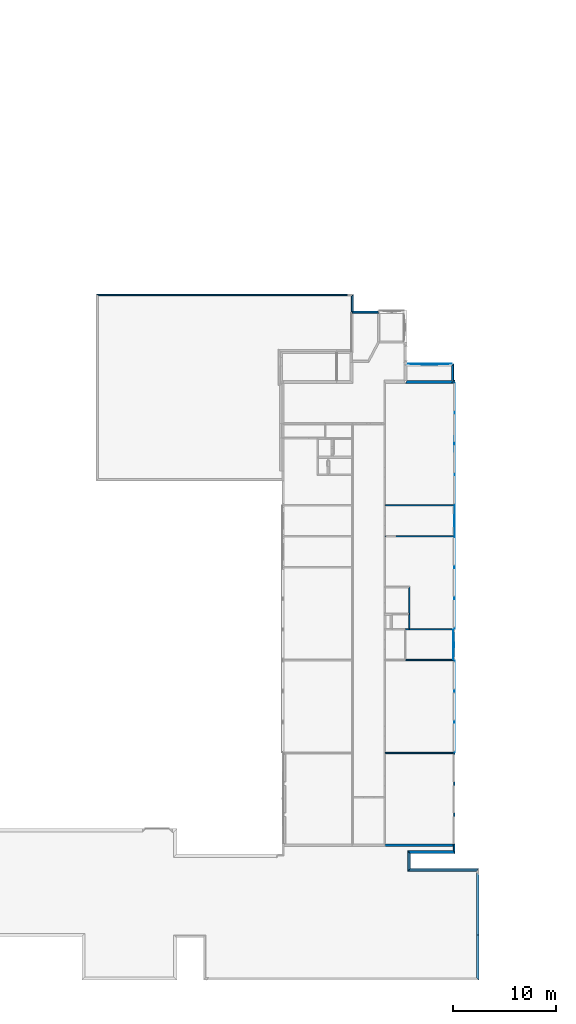
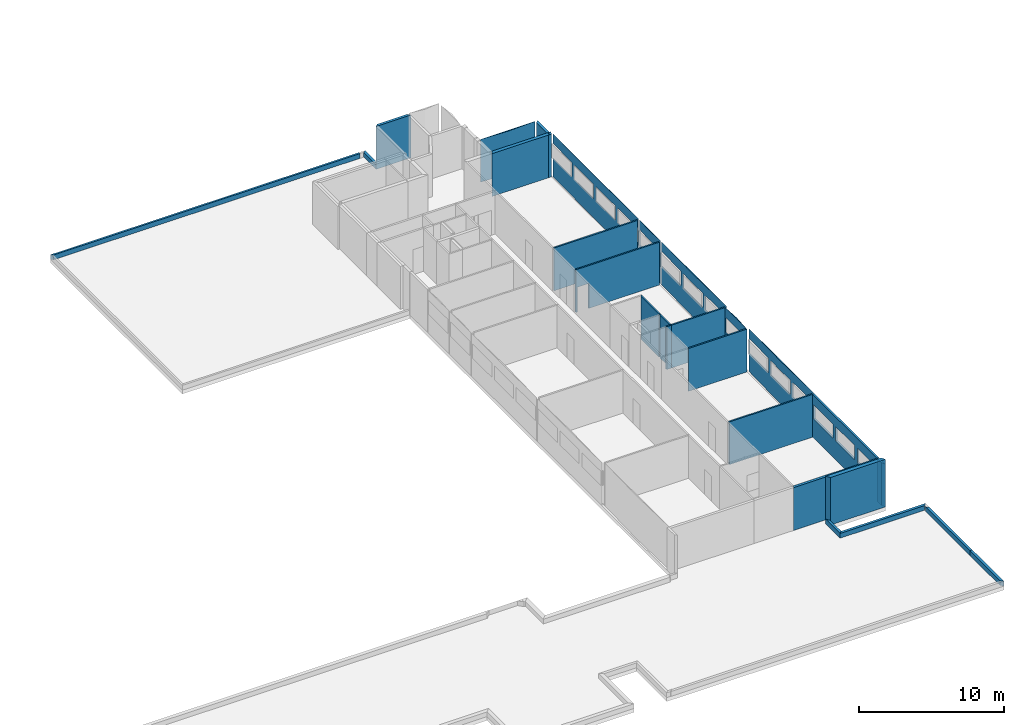
# One storey, part 5 of 72: 28 walls, 16 openings.
"""IFC2X3 building model written with IfcOpenShell, lengths in metres."""

from ifc_helpers import new_model, entity, si_unit, converted_unit, derived_unit, frame, origin_with_axes, place, context, project, spatial, polyline, outline, extrude, material, layer, layer_set, layer_usage, element, save


model = new_model("IFC2X3")

# Units and contexts
context_of_model_1 = context(None, 3, world=origin_with_axes())
context_of_model_2 = context(None, 3, world=origin_with_axes())
context_of_model_3 = context(None, 2, world=origin_with_axes())
context_of_model_4 = context(None, 3, world=origin_with_axes())
ifc_project = project(units=[si_unit("LENGTHUNIT", "METRE"), si_unit("AREAUNIT", "SQUARE_METRE"), si_unit("ELECTRICCURRENTUNIT", "AMPERE"), si_unit("ELECTRICVOLTAGEUNIT", "VOLT"), si_unit("ELECTRICRESISTANCEUNIT", "OHM"), si_unit("POWERUNIT", "WATT"), si_unit("MASSUNIT", "GRAM"), si_unit("SOLIDANGLEUNIT", "STERADIAN"), si_unit("THERMODYNAMICTEMPERATUREUNIT", "KELVIN"), si_unit("PRESSUREUNIT", "PASCAL"), si_unit("LUMINOUSFLUXUNIT", "LUMEN"), si_unit("ILLUMINANCEUNIT", "LUX"), si_unit("FREQUENCYUNIT", "HERTZ"), si_unit("VOLUMEUNIT", "CUBIC_METRE"), si_unit("TIMEUNIT", "SECOND"), derived_unit("VOLUMETRICFLOWRATEUNIT", [(si_unit("TIMEUNIT", "SECOND"), -1), (si_unit("VOLUMEUNIT", "CUBIC_METRE"), 1)]), derived_unit("THERMALTRANSMITTANCEUNIT", [(si_unit("AREAUNIT", "SQUARE_METRE"), -1), (si_unit("THERMODYNAMICTEMPERATUREUNIT", "KELVIN"), -1), (si_unit("POWERUNIT", "WATT"), 1)]), converted_unit("PLANEANGLEUNIT", "DEGREE", entity("IfcPlaneAngleMeasure", 57.29577951308232), si_unit("PLANEANGLEUNIT", "RADIAN"), dimensions=[0, 0, 0, 0, 0, 0, 0])], contexts=[context_of_model_1, context_of_model_2, context_of_model_3, context_of_model_4])

# Site, building, storey
site = spatial("IfcSite", under=ifc_project, CompositionType="ELEMENT")
building_placement = place(None, origin_with_axes())
building = spatial("IfcBuilding", under=site, at=building_placement, Name="200", CompositionType="ELEMENT")
storey_placement = place(building_placement, frame((0.0, 0.0, 15.68000030517578), z_axis=(0.0, 0.0, 1.0), x_axis=(1.0, 0.0, 0.0)))
storey = spatial("IfcBuildingStorey", under=building, at=storey_placement, Name="3.etasje", CompositionType="ELEMENT", Elevation=15.68000030517578)

# Walls
ifc_material_1 = material(Name="Layer-YV04 20 cm")
ifc_layer_1 = layer(ifc_material_1, 0.2000000029802322, ventilated=False)
ifc_layer_set_1 = layer_set([ifc_layer_1])
ifc_layer_usage_1 = layer_usage(ifc_layer_set_1, "AXIS2", "POSITIVE", 0.0)
wall_1_placement = place(storey_placement, frame((12.73623752593994, -12.12827587127686, 0.0), z_axis=(0.0, 0.0, 1.0), x_axis=(-4.371138828673793e-08, 1.0, 0.0)))
element("IfcWallStandardCase", 1, at=wall_1_placement, inside=storey, material=ifc_layer_usage_1, Name="YV04 20 cm", context=context_of_model_1, shape_type="SweptSolid", body=[
    extrude(outline(polyline([(0.0, 0.0), (4.360269546508788, 0.0), (4.360269546508788, 0.1999998092651369), (0.1999998092651382, 0.2000017166137685), (0.0, 0.0)])), frame((0.0, 0.0, 0.0), z_axis=(0.0, 0.0, 1.0), x_axis=(0.9999999999999992, -4.371139013701908e-08, 0.0)), (0.0, 0.0, 1.0), 0.4),
])
wall_2_placement = place(storey_placement, frame((12.73623752593994, -7.768006324768066, 0.0), z_axis=(0.0, 0.0, 1.0), x_axis=(-4.371138828673793e-08, 1.0, 0.0)))
element("IfcWallStandardCase", 2, at=wall_2_placement, inside=storey, material=ifc_layer_usage_1, Name="YV04 20 cm", context=context_of_model_1, shape_type="SweptSolid", body=[
    extrude(outline(polyline([(0.0, 0.0), (5.894350409507751, 0.0), (6.094350337982176, 0.1999998092651373), (-5.330077061348608e-16, 0.1999998092651369), (0.0, 0.0)])), frame((0.0, 0.0, 0.0), z_axis=(0.0, 0.0, 1.0), x_axis=(0.9999999999999991, -4.371139000564226e-08, 0.0)), (0.0, 0.0, 1.0), 0.4),
])
wall_3_placement = place(storey_placement, frame((12.73922824859619, -1.31800639629364, 0.0), z_axis=(0.0, 0.0, 1.0), x_axis=(-1.0, 1.509958025280866e-07, 0.0)))
element("IfcWallStandardCase", 3, at=wall_3_placement, inside=storey, material=ifc_layer_usage_1, Name="YV04 20 cm", context=context_of_model_1, shape_type="SweptSolid", body=[
    extrude(outline(polyline([(0.0, 0.0), (6.699837684631374, 0.0), (6.899837476103643, 0.2000000654765604), (0.199999791472271, 0.2000000654765604), (0.0, 0.0)])), frame((0.0, 0.0, 0.0), z_axis=(0.0, 0.0, 1.0), x_axis=(0.9999999999999981, 6.203148745014698e-08, 0.0)), (0.0, 0.0, 1.0), 0.4),
])
wall_4_placement = place(storey_placement, frame((6.039390563964844, -1.318005800247192, 0.0), z_axis=(0.0, 0.0, 1.0), x_axis=(-4.371138828673793e-08, 1.0, 0.0)))
element("IfcWallStandardCase", 4, at=wall_4_placement, inside=storey, material=ifc_layer_usage_1, Name="YV04 20 cm", context=context_of_model_1, shape_type="SweptSolid", body=[
    extrude(outline(polyline([(0.0, 0.0), (1.49888500571251, 0.0), (1.798884987831116, 0.1999998092651371), (-0.2000000476837157, 0.1999998092651366), (0.0, 0.0)])), frame((0.0, 0.0, 0.0), z_axis=(0.0, 0.0, 1.0), x_axis=(0.999999999999999, -4.371139009486238e-08, 0.0)), (0.0, 0.0, 1.0), 0.4),
])
ifc_material_2 = material(Name="Layer-YV3 30 cm")
ifc_layer_2 = layer(ifc_material_2, 0.300000011920929, ventilated=False)
ifc_layer_set_2 = layer_set([ifc_layer_2])
ifc_layer_usage_2 = layer_usage(ifc_layer_set_2, "AXIS2", "POSITIVE", 0.0)
wall_5_placement = place(storey_placement, frame((6.039390563964844, 0.1808792054653168, 0.0), z_axis=(0.0, 0.0, 1.0), x_axis=(1.0, 6.81067069407959e-09, 0.0)))
element("IfcWallStandardCase", 5, at=wall_5_placement, inside=storey, material=ifc_layer_usage_2, Name="YV3 30 cm", context=context_of_model_1, shape_type="SweptSolid", body=[
    extrude(outline(polyline([(0.0, 0.0), (4.375827789306641, 0.0), (4.224827768461658, 0.3000000129493404), (-0.1999998072219355, 0.3000000728877066), (0.0, 0.0)])), frame((0.0, 0.0, 0.0), z_axis=(0.0, 0.0, 1.0), x_axis=(1.0, 6.977224572640124e-17, 0.0)), (0.0, 0.0, 1.0), 4.0),
])
ifc_material_3 = material(Name="Layer-YV3 15 cm")
ifc_layer_3 = layer(ifc_material_3, 0.1507492065429688, ventilated=False)
ifc_layer_set_3 = layer_set([ifc_layer_3])
ifc_layer_usage_3 = layer_usage(ifc_layer_set_3, "AXIS2", "POSITIVE", 0.0)
wall_6_placement = place(storey_placement, frame((10.41521835327148, 0.1808792352676392, 0.0), z_axis=(0.0, 0.0, 1.0), x_axis=(-4.371138828673793e-08, 1.0, 0.0)))
element("IfcWallStandardCase", 6, at=wall_6_placement, inside=storey, material=ifc_layer_usage_3, Name="YV3 15 cm", context=context_of_model_1, shape_type="SweptSolid", body=[
    extrude(outline(polyline([(0.0, 0.0), (0.9119060039520263, 6.617444900424221e-24), (0.9119060039520264, 0.1510000228881837), (0.300000011920929, 0.1510000228881831), (0.0, 0.0)])), frame((0.0, 0.0, 0.0), z_axis=(0.0, 0.0, 1.0), x_axis=(0.9999999999999991, -4.371138926696568e-08, 0.0)), (0.0, 0.0, 1.0), 3.6),
])
ifc_material_4 = material(Name="Layer-YV3 15 cm")
ifc_layer_4 = layer(ifc_material_4, 0.2713470458984375, ventilated=False)
ifc_layer_set_4 = layer_set([ifc_layer_4])
ifc_layer_usage_4 = layer_usage(ifc_layer_set_4, "AXIS2", "POSITIVE", 0.0)
wall_7_placement = place(storey_placement, frame((10.41521644592285, 46.24888610839844, 0.0), z_axis=(0.0, 0.0, 1.0), x_axis=(-1.0, -8.742277657347586e-08, 0.0)))
element("IfcWallStandardCase", 7, at=wall_7_placement, inside=storey, material=ifc_layer_usage_4, Name="YV3 15 cm", context=context_of_model_1, shape_type="SweptSolid", body=[
    extrude(outline(polyline([(0.0, 0.0), (0.1205959320068364, 0.0), (0.3205957412719667, 0.2713470458984368), (0.1004962921142528, 0.2713470458984298), (0.0, 0.0)])), frame((0.0, 0.0, 0.0), z_axis=(0.0, 0.0, 1.0), x_axis=(0.9999999999999962, -8.742280096682447e-08, 0.0)), (0.0, 0.0, 1.0), 3.6),
])
wall_8_placement = place(storey_placement, frame((2.875983953475952, 53.00139999389648, 0.0), z_axis=(0.0, 0.0, 1.0), x_axis=(-1.0, -8.742277657347586e-08, 0.0)))
element("IfcWallStandardCase", 8, at=wall_8_placement, inside=storey, material=ifc_layer_usage_1, Name="YV04 20 cm", context=context_of_model_1, shape_type="SweptSolid", body=[
    extrude(outline(polyline([(0.0, 0.0), (2.372065007686615, 0.0), (2.572064876556397, 0.200000762939453), (-0.2000000476837156, 0.2000007629394535), (0.0, 0.0)])), frame((0.0, 0.0, 0.0), z_axis=(0.0, 0.0, 1.0), x_axis=(0.9999999999999962, -8.742277927956448e-08, 0.0)), (0.0, 0.0, 1.0), 3.6),
])
wall_9_placement = place(storey_placement, frame((0.5039189457893372, 53.00139999389648, 0.0), z_axis=(0.0, 0.0, 1.0), x_axis=(-4.371138828673793e-08, 1.0, 0.0)))
element("IfcWallStandardCase", 9, at=wall_9_placement, inside=storey, material=ifc_layer_usage_1, Name="YV04 20 cm", context=context_of_model_1, shape_type="SweptSolid", body=[
    extrude(outline(polyline([(0.0, 0.0), (1.641052246093743, 0.0), (1.491050727479033, 0.199999993527275), (-0.2000007556752632, 0.1999999357386521), (0.0, 0.0)])), frame((0.0, 0.0, 0.0), z_axis=(0.0, 0.0, 1.0), x_axis=(1.0, -7.390398479739984e-09, 0.0)), (0.0, 0.0, 1.0), 0.4),
])
ifc_material_5 = material(Name="Layer-YV3 15 cm")
ifc_layer_5 = layer(ifc_material_5, 0.1500000059604645, ventilated=False)
ifc_layer_set_5 = layer_set([ifc_layer_5])
ifc_layer_usage_5 = layer_usage(ifc_layer_set_5, "AXIS2", "POSITIVE", 0.0)
wall_10_placement = place(storey_placement, frame((1.370906829833984e-06, 54.64245223999023, 0.0), z_axis=(0.0, 0.0, 1.0), x_axis=(-1.0, -8.742277657347586e-08, 0.0)))
element("IfcWallStandardCase", 10, at=wall_10_placement, inside=storey, material=ifc_layer_usage_5, Name="YV3 15 cm", context=context_of_model_1, shape_type="SweptSolid", body=[
    extrude(outline(polyline([(0.0, 0.0), (24.49093002080918, 0.0), (24.3409304022789, 0.1500015258789091), (-5.872947607540769e-18, 0.1500015258789068), (0.0, 0.0)])), frame((0.0, 0.0, 0.0), z_axis=(0.0, 0.0, 1.0), x_axis=(0.9999999999999962, -8.742278004287902e-08, 0.0)), (0.0, 0.0, 1.0), 0.4),
])
ifc_material_6 = material()
ifc_layer_6 = layer(ifc_material_6, 0.2713546752929688, ventilated=False)
ifc_layer_set_6 = layer_set([ifc_layer_6])
ifc_layer_usage_6 = layer_usage(ifc_layer_set_6, "AXIS2", "POSITIVE", 0.0)
wall_11_placement = place(storey_placement, frame((5.597535610198975, 45.9775390625, 0.0), z_axis=(0.0, 0.0, 1.0), x_axis=(1.0, 0.0, 0.0)))
element("IfcWallStandardCase", 11, at=wall_11_placement, inside=storey, material=ifc_layer_usage_6, context=context_of_model_1, shape_type="SweptSolid", body=[
    extrude(outline(polyline([(0.0, 0.0), (4.717184543609619, 0.0), (4.497085094451904, 0.2713470458984375), (0.1507501602172852, 0.2713470458984375), (0.0, 0.0)])), origin_with_axes(), (0.0, 0.0, 1.0), 3.6),
])
wall_12_placement = place(storey_placement, frame((10.29462051391602, 46.24888610839844, 0.0), z_axis=(0.0, 0.0, 1.0), x_axis=(-4.371138828673793e-08, 1.0, 0.0)))
element("IfcWallStandardCase", 12, at=wall_12_placement, inside=storey, material=ifc_layer_usage_1, Name="YV04 20 cm", context=context_of_model_1, shape_type="SweptSolid", body=[
    extrude(outline(polyline([(0.0, 0.0), (1.618358612060549, 0.0), (1.418357849121095, 0.1999998092651374), (-4.712814208746225e-16, 0.1999998092651369), (0.0, 0.0)])), frame((0.0, 0.0, 0.0), z_axis=(0.0, 0.0, 1.0), x_axis=(0.999999999999999, -4.371138969701054e-08, 0.0)), (0.0, 0.0, 1.0), 3.6),
])
wall_13_placement = place(storey_placement, frame((10.09462070465088, 47.66724395751953, 0.0), z_axis=(0.0, 0.0, 1.0), x_axis=(-1.0, -8.742277657347586e-08, 0.0)))
element("IfcWallStandardCase", 13, at=wall_13_placement, inside=storey, material=ifc_layer_usage_1, Name="YV04 20 cm", context=context_of_model_1, shape_type="SweptSolid", body=[
    extrude(outline(polyline([(0.0, 0.0), (4.346334934234621, 0.0), (9.264004803512326e-16, 0.2000007629394539), (4.346334934234621, 0.2000007629394539), (0.0, 0.0)])), frame((0.0, 0.0, 0.0), z_axis=(0.0, 0.0, -1.0), x_axis=(0.9999999999999961, -8.742277989276747e-08, 0.0)), (0.0, 0.0, -1.0), 3.6),
])
ifc_material_7 = material()
ifc_layer_7 = layer(ifc_material_7, 0.2000000029802322, ventilated=False)
ifc_layer_set_7 = layer_set([ifc_layer_7])
ifc_layer_usage_7 = layer_usage(ifc_layer_set_7, "AXIS2", "POSITIVE", 0.0)
wall_14_placement = place(storey_placement, frame((3.517215251922607, 0.892785370349884, 0.0), z_axis=(0.0, 0.0, 1.0), x_axis=(1.0, -1.728171028503311e-08, 0.0)))
element("IfcWallStandardCase", 14, at=wall_14_placement, inside=storey, material=ifc_layer_usage_7, context=context_of_model_1, shape_type="SweptSolid", body=[
    extrude(outline(polyline([(0.0, 0.0), (6.898003101348877, 0.0), (6.747254845023884, 0.1999999854738835), (0.1205987895734455, 0.1999998709539348), (0.0, 0.0)])), frame((0.0, 0.0, 0.0), z_axis=(0.0, 0.0, 1.0), x_axis=(1.0, 2.253278538206629e-16, 0.0)), (0.0, 0.0, 1.0), 3.6),
])

# Wall, openings
wall_15_placement = place(storey_placement, frame((10.41521835327148, 1.092785239219666, 0.0), z_axis=(0.0, 0.0, 1.0), x_axis=(-4.371138828673793e-08, 1.0, 0.0)))
wall_15 = element("IfcWallStandardCase", 15, at=wall_15_placement, inside=storey, material=ifc_layer_usage_3, Name="YV3 15 cm", context=context_of_model_1, shape_type="SweptSolid", body=[
    extrude(outline(polyline([(0.0, 0.0), (8.893602013587952, 0.0), (8.8333021402359, 0.1507482528686515), (2.386872670913614e-18, 0.1507482528686525), (0.0, 0.0)])), frame((0.0, 0.0, 0.0), z_axis=(0.0, 0.0, 1.0), x_axis=(0.999999999999999, -4.371139002933706e-08, 0.0)), (0.0, 0.0, 1.0), 3.6),
])
opening_1_placement = place(wall_15_placement, frame((0.03767181101751627, 0.1507482512219642, 1.6), z_axis=(0.0, 0.0, 1.0), x_axis=(1.0, 0.0, 0.0)))
element("IfcOpeningElement", 16, at=opening_1_placement, cuts=wall_15, context=context_of_model_1, shape_type="SweptSolid", body=[
    extrude(outline(polyline([(0.0, 0.0), (1.200000047683716, 0.0), (1.200000047683716, 2.658), (0.0, 2.658), (0.0, 0.0)])), frame((0.0, 0.0, 0.0), z_axis=(4.371139016334065e-08, 0.999999999999999, 0.0), x_axis=(0.0, 0.0, 1.0)), (0.0, 4.371139016334065e-08, -0.9999999999999991), 0.1507479793622988),
])
opening_2_placement = place(wall_15_placement, frame((3.051244861516475, 0.150748119494498, 1.6), z_axis=(0.0, 0.0, 1.0), x_axis=(1.0, 0.0, 0.0)))
element("IfcOpeningElement", 17, at=opening_2_placement, cuts=wall_15, context=context_of_model_1, shape_type="SweptSolid", body=[
    extrude(outline(polyline([(0.0, 0.0), (1.200000047683716, 0.0), (1.200000047683716, 2.658), (0.0, 2.658), (0.0, 0.0)])), frame((0.0, 0.0, 0.0), z_axis=(4.371139016334065e-08, 0.999999999999999, 0.0), x_axis=(0.0, 0.0, 1.0)), (0.0, 4.371139016334065e-08, -0.9999999999999991), 0.1507479793622988),
])
opening_3_placement = place(wall_15_placement, frame((6.062531597051141, 0.1507479878669695, 1.6), z_axis=(0.0, 0.0, 1.0), x_axis=(1.0, 0.0, 0.0)))
element("IfcOpeningElement", 18, at=opening_3_placement, cuts=wall_15, context=context_of_model_1, shape_type="SweptSolid", body=[
    extrude(outline(polyline([(0.0, 0.0), (1.200000047683716, 0.0), (1.200000047683716, 2.657999999999999), (0.0, 2.657999999999999), (0.0, 0.0)])), frame((0.0, 0.0, 0.0), z_axis=(4.371139016334066e-08, 0.999999999999999, 0.0), x_axis=(0.0, 0.0, 1.0)), (0.0, 4.371139016334067e-08, -0.9999999999999992), 0.1507479793622988),
])

# Wall
ifc_material_8 = material()
ifc_layer_8 = layer(ifc_material_8, 0.121002197265625, ventilated=False)
ifc_layer_set_8 = layer_set([ifc_layer_8])
ifc_layer_usage_8 = layer_usage(ifc_layer_set_8, "AXIS2", "POSITIVE", 0.0)
wall_16_placement = place(storey_placement, frame((10.26447010040283, 10.04668712615967, 0.0), z_axis=(0.0, 0.0, 1.0), x_axis=(-1.0, -8.742277657347586e-08, 0.0)))
element("IfcWallStandardCase", 19, at=wall_16_placement, inside=storey, material=ifc_layer_usage_8, context=context_of_model_1, shape_type="SweptSolid", body=[
    extrude(outline(polyline([(0.0, 0.0), (6.626655817031862, 0.0), (6.62665605545044, 0.1205997467041033), (-5.852870015015086e-16, 0.120599746704102), (0.0, 0.0)])), frame((0.0, 0.0, 0.0), z_axis=(0.0, 0.0, 1.0), x_axis=(0.9999999999999961, -8.742278020508375e-08, 0.0)), (0.0, 0.0, 1.0), 3.6),
])

# Wall, openings
wall_17_placement = place(storey_placement, frame((10.26447010040283, 10.04668712615967, 0.0), z_axis=(0.0, 0.0, 1.0), x_axis=(-4.371138828673793e-08, 1.0, 0.0)))
wall_17 = element("IfcWallStandardCase", 20, at=wall_17_placement, inside=storey, material=ifc_layer_usage_3, Name="YV3 15 cm", context=context_of_model_1, shape_type="SweptSolid", body=[
    extrude(outline(polyline([(0.0, 0.0), (8.921465873718263, 5.293955920339377e-23), (-1.336499008280796e-15, 0.1507482528686525), (8.921465873718265, 0.1507482528686525), (0.0, 0.0)])), frame((0.0, 0.0, 0.0), z_axis=(0.0, 0.0, -1.0), x_axis=(0.999999999999999, -4.371139001710141e-08, 0.0)), (0.0, 0.0, -1.0), 3.6),
])
opening_4_placement = place(wall_17_placement, frame((0.1222047805786133, -5.341741271536193e-09, 1.6), z_axis=(0.0, 0.0, 1.0), x_axis=(1.0, 0.0, 0.0)))
element("IfcOpeningElement", 21, at=opening_4_placement, cuts=wall_17, context=context_of_model_1, shape_type="SweptSolid", body=[
    extrude(outline(polyline([(0.0, 0.0), (1.200000047683716, 0.0), (1.200000047683716, 2.658223152160645), (0.0, 2.658223152160645), (0.0, 0.0)])), frame((0.0, 0.0, 0.0), z_axis=(4.371139004455655e-08, 0.999999999999999, 0.0), x_axis=(0.0, 0.0, 1.0)), (0.0, 4.371139004455655e-08, -0.9999999999999991), 0.1507478970506907),
])
opening_5_placement = place(wall_17_placement, frame((3.135777473449705, -1.370691915525413e-07, 1.6), z_axis=(0.0, 0.0, 1.0), x_axis=(1.0, 0.0, 0.0)))
element("IfcOpeningElement", 22, at=opening_5_placement, cuts=wall_17, context=context_of_model_1, shape_type="SweptSolid", body=[
    extrude(outline(polyline([(0.0, 0.0), (1.200000047683716, 0.0), (1.200000047683716, 2.658223152160643), (0.0, 2.658223152160643), (0.0, 0.0)])), frame((0.0, 0.0, 0.0), z_axis=(4.371139004455659e-08, 0.999999999999999, 0.0), x_axis=(0.0, 0.0, 1.0)), (0.0, 4.371139004455659e-08, -0.9999999999999991), 0.1507478970506907),
])
opening_6_placement = place(wall_17_placement, frame((6.14706325531005, -2.686966791287659e-07, 1.6), z_axis=(0.0, 0.0, 1.0), x_axis=(1.0, 0.0, 0.0)))
element("IfcOpeningElement", 23, at=opening_6_placement, cuts=wall_17, context=context_of_model_1, shape_type="SweptSolid", body=[
    extrude(outline(polyline([(0.0, 0.0), (1.200000047683716, 0.0), (1.200000047683716, 2.658226013183596), (0.0, 2.658226013183596), (0.0, 0.0)])), frame((0.0, 0.0, 0.0), z_axis=(4.371138977583923e-08, 0.999999999999999, 0.0), x_axis=(0.0, 0.0, 1.0)), (0.0, 4.371138977583923e-08, -0.9999999999999992), 0.1507478970506907),
])

# Wall
ifc_material_9 = material()
ifc_layer_9 = layer(ifc_material_9, 0.1205999851226807, ventilated=False)
ifc_layer_set_9 = layer_set([ifc_layer_9])
ifc_layer_usage_9 = layer_usage(ifc_layer_set_9, "AXIS2", "POSITIVE", 0.0)
wall_18_placement = place(storey_placement, frame((10.26447010040283, 19.08875274658203, 0.0), z_axis=(0.0, 0.0, 1.0), x_axis=(-1.0, -8.742277657347586e-08, 0.0)))
element("IfcWallStandardCase", 24, at=wall_18_placement, inside=storey, material=ifc_layer_usage_9, context=context_of_model_1, shape_type="SweptSolid", body=[
    extrude(outline(polyline([(0.0, 0.0), (4.616654396057129, 5.293955920339377e-23), (4.66690492630005, 0.1205997467041025), (-5.63108305699853e-16, 0.120599746704102), (0.0, 0.0)])), frame((0.0, 0.0, 0.0), z_axis=(0.0, 0.0, 1.0), x_axis=(0.9999999999999961, -8.742278002118041e-08, 0.0)), (0.0, 0.0, 1.0), 3.6),
])

# Wall, opening
wall_19_placement = place(storey_placement, frame((10.26447010040283, 19.08875274658203, 0.0), z_axis=(0.0, 0.0, 1.0), x_axis=(-4.371138828673793e-08, 1.0, 0.0)))
wall_19 = element("IfcWallStandardCase", 25, at=wall_19_placement, inside=storey, material=ifc_layer_usage_3, Name="YV3 15 cm", context=context_of_model_1, shape_type="SweptSolid", body=[
    extrude(outline(polyline([(0.0, 0.0), (2.879892349243163, 0.0), (2.222884016867664e-15, 0.1507482528686525), (2.879892349243165, 0.1507482528686525), (0.0, 0.0)])), frame((0.0, 0.0, 0.0), z_axis=(0.0, 0.0, -1.0), x_axis=(0.9999999999999991, -4.371139006134301e-08, 0.0)), (0.0, 0.0, -1.0), 3.6),
])
opening_7_placement = place(wall_19_placement, frame((0.1162853240966797, -5.082993581595474e-09, 1.6), z_axis=(0.0, 0.0, 1.0), x_axis=(1.0, 0.0, 0.0)))
element("IfcOpeningElement", 26, at=opening_7_placement, cuts=wall_19, context=context_of_model_1, shape_type="SweptSolid", body=[
    extrude(outline(polyline([(0.0, 0.0), (1.200000047683716, 0.0), (1.200000047683716, 2.658226013183593), (0.0, 2.658226013183593), (0.0, 0.0)])), frame((0.0, 0.0, 0.0), z_axis=(4.371138977583929e-08, 0.999999999999999, 0.0), x_axis=(0.0, 0.0, 1.0)), (0.0, 4.371138977583929e-08, -0.9999999999999992), 0.1507480645228533),
])

# Walls
wall_20_placement = place(storey_placement, frame((10.26447010040283, 22.08924674987793, 0.0), z_axis=(0.0, 0.0, 1.0), x_axis=(-1.0, -8.742277657347586e-08, 0.0)))
element("IfcWallStandardCase", 27, at=wall_20_placement, inside=storey, material=ifc_layer_usage_9, context=context_of_model_1, shape_type="SweptSolid", body=[
    extrude(outline(polyline([(0.0, 0.0), (4.226655006408691, 0.0), (4.288655281066894, 0.1206016540527345), (-3.028357307454183e-16, 0.1206016540527348), (0.0, 0.0)])), frame((0.0, 0.0, 0.0), z_axis=(0.0, 0.0, 1.0), x_axis=(0.9999999999999962, -8.742277978528296e-08, 0.0)), (0.0, 0.0, 1.0), 3.6),
])
wall_21_placement = place(storey_placement, frame((5.913814544677734, 22.08924674987793, 0.0), z_axis=(0.0, 0.0, 1.0), x_axis=(-1.0, -8.742277657347586e-08, 0.0)))
element("IfcWallStandardCase", 28, at=wall_21_placement, inside=storey, material=ifc_layer_usage_8, context=context_of_model_1, shape_type="SweptSolid", body=[
    extrude(outline(polyline([(0.0, 0.0), (0.3162493705749515, 0.0), (0.2659988403320311, 0.1206016540527344), (-0.06200027465820365, 0.1206016540527352), (0.0, 0.0)])), frame((0.0, 0.0, 0.0), z_axis=(0.0, 0.0, 1.0), x_axis=(0.9999999999999961, -8.742277964556659e-08, 0.0)), (0.0, 0.0, 1.0), 3.6),
])

# Wall, openings
wall_22_placement = place(storey_placement, frame((10.26447010040283, 22.08924674987793, 0.0), z_axis=(0.0, 0.0, 1.0), x_axis=(-4.371138828673793e-08, 1.0, 0.0)))
wall_22 = element("IfcWallStandardCase", 29, at=wall_22_placement, inside=storey, material=ifc_layer_usage_3, Name="YV3 15 cm", context=context_of_model_1, shape_type="SweptSolid", body=[
    extrude(outline(polyline([(0.0, 0.0), (8.93182373046875, 0.0), (2.211804669580442e-15, 0.1507482528686525), (8.931823730468748, 0.1507472991943361), (0.0, 0.0)])), frame((0.0, 0.0, 0.0), z_axis=(0.0, 0.0, -1.0), x_axis=(0.999999999999999, -4.371138998784733e-08, 0.0)), (0.0, 0.0, -1.0), 3.6),
])
opening_8_placement = place(wall_22_placement, frame((0.1242580413818359, -5.431491700846891e-09, 1.6), z_axis=(0.0, 0.0, 1.0), x_axis=(1.0, 0.0, 0.0)))
element("IfcOpeningElement", 30, at=opening_8_placement, cuts=wall_22, context=context_of_model_1, shape_type="SweptSolid", body=[
    extrude(outline(polyline([(0.0, 0.0), (1.200000047683716, 0.0), (1.200000047683716, 2.65822410583496), (0.0, 2.65822410583496), (0.0, 0.0)])), frame((0.0, 0.0, 0.0), z_axis=(4.371138973223426e-08, 0.999999999999999, 0.0), x_axis=(0.0, 0.0, 1.0)), (0.0, 4.371138973223427e-08, -0.9999999999999992), 0.1507475447914773),
])
opening_9_placement = place(wall_22_placement, frame((3.133426666259762, -1.369664346384525e-07, 1.6), z_axis=(0.0, 0.0, 1.0), x_axis=(1.0, 0.0, 0.0)))
element("IfcOpeningElement", 31, at=opening_9_placement, cuts=wall_22, context=context_of_model_1, shape_type="SweptSolid", body=[
    extrude(outline(polyline([(0.0, 0.0), (1.200000047683716, 0.0), (1.200000047683716, 2.658226013183593), (0.0, 2.658226013183593), (0.0, 0.0)])), frame((0.0, 0.0, 0.0), z_axis=(4.371139044408828e-08, 0.999999999999999, 0.0), x_axis=(0.0, 0.0, 1.0)), (0.0, 4.371139044408828e-08, -0.9999999999999992), 0.1507475447914773),
])
opening_10_placement = place(wall_22_placement, frame((6.155366897583001, -2.690596438981174e-07, 1.6), z_axis=(0.0, 0.0, 1.0), x_axis=(1.0, 0.0, 0.0)))
element("IfcOpeningElement", 32, at=opening_10_placement, cuts=wall_22, context=context_of_model_1, shape_type="SweptSolid", body=[
    extrude(outline(polyline([(0.0, 0.0), (1.200000047683716, 0.0), (1.200000047683716, 2.658227920532225), (0.0, 2.658227920532225), (0.0, 0.0)])), frame((0.0, 0.0, 0.0), z_axis=(4.371138981944425e-08, 0.999999999999999, 0.0), x_axis=(0.0, 0.0, 1.0)), (0.0, 4.371138981944425e-08, -0.9999999999999991), 0.1507475447914773),
])

# Wall, opening
wall_23_placement = place(storey_placement, frame((10.26447010040283, 31.14167213439941, 0.0), z_axis=(0.0, 0.0, 1.0), x_axis=(-1.0, -8.742277657347586e-08, 0.0)))
wall_23 = element("IfcWallStandardCase", 33, at=wall_23_placement, inside=storey, material=ifc_layer_usage_8, context=context_of_model_1, shape_type="SweptSolid", body=[
    extrude(outline(polyline([(0.0, 0.0), (6.626655340194701, 0.0), (6.626655340194701, 0.1206016540527348), (-3.039164951552781e-16, 0.1206016540527348), (0.0, 0.0)])), frame((0.0, 0.0, 0.0), z_axis=(0.0, 0.0, 1.0), x_axis=(0.9999999999999962, -8.742277979424439e-08, 0.0)), (0.0, 0.0, 1.0), 3.6),
])
opening_11_placement = place(wall_23_placement, frame((5.615690718703711, 0.1206011631134416, 0.0), z_axis=(0.0, 0.0, 1.0), x_axis=(1.0, 0.0, 0.0)))
element("IfcOpeningElement", 34, at=opening_11_placement, cuts=wall_23, context=context_of_model_1, shape_type="SweptSolid", body=[
    extrude(outline(polyline([(0.0, 0.0), (2.099999904632568, 0.0), (2.099999904632568, 0.9145500659942627), (0.0, 0.9145500659942627), (0.0, 0.0)])), frame((0.0, 0.0, 0.0), z_axis=(8.742277739647082e-08, 0.9999999999999962, 0.0), x_axis=(0.0, 0.0, 1.0)), (0.0, 8.742277739647082e-08, -0.9999999999999962), 0.1206016540527344),
])

# Walls
ifc_material_10 = material()
ifc_layer_10 = layer(ifc_material_10, 0.1238250732421875, ventilated=False)
ifc_layer_set_10 = layer_set([ifc_layer_10])
ifc_layer_usage_10 = layer_usage(ifc_layer_set_10, "AXIS2", "POSITIVE", 0.0)
wall_24_placement = place(storey_placement, frame((5.913814544677734, 26.06524467468262, 0.0), z_axis=(0.0, 0.0, 1.0), x_axis=(-4.371138828673793e-08, -1.0, 0.0)))
element("IfcWallStandardCase", 35, at=wall_24_placement, inside=storey, material=ifc_layer_usage_10, context=context_of_model_1, shape_type="SweptSolid", body=[
    extrude(outline(polyline([(0.0, 0.0), (2.499856948852541, 0.0), (2.561857223510744, 0.1240005493164056), (-0.1240005493164067, 0.1240005493164061), (0.0, 0.0)])), frame((0.0, 0.0, 0.0), z_axis=(0.0, 0.0, 1.0), x_axis=(0.9999999999999991, 4.371139013847142e-08, 0.0)), (0.0, 0.0, 1.0), 3.6),
])
wall_25_placement = place(storey_placement, frame((5.913814544677734, 23.44138908386231, 0.0), z_axis=(0.0, 0.0, 1.0), x_axis=(-4.371138828673793e-08, -1.0, 0.0)))
element("IfcWallStandardCase", 36, at=wall_25_placement, inside=storey, material=ifc_layer_usage_10, context=context_of_model_1, shape_type="SweptSolid", body=[
    extrude(outline(polyline([(0.0, 0.0), (1.352142333984373, 0.0), (1.352142333984373, 0.1240005493164064), (-0.06199836730957069, 0.1240005493164064), (0.0, 0.0)])), frame((0.0, 0.0, 0.0), z_axis=(0.0, 0.0, 1.0), x_axis=(0.999999999999999, 4.371139024884114e-08, 0.0)), (0.0, 0.0, 1.0), 3.6),
])

# Wall, opening
wall_26_placement = place(storey_placement, frame((10.26447010040283, 31.14167213439941, 0.0), z_axis=(0.0, 0.0, 1.0), x_axis=(-4.371138828673793e-08, 1.0, 0.0)))
wall_26 = element("IfcWallStandardCase", 37, at=wall_26_placement, inside=storey, material=ifc_layer_usage_3, Name="YV3 15 cm", context=context_of_model_1, shape_type="SweptSolid", body=[
    extrude(outline(polyline([(0.0, 0.0), (2.893617630004882, 2.646977960169689e-23), (-3.322798351085354e-16, 0.1507472991943361), (2.893617630004882, 0.1507472991943361), (0.0, 0.0)])), frame((0.0, 0.0, 0.0), z_axis=(0.0, 0.0, -1.0), x_axis=(0.9999999999999991, -4.371139040241523e-08, 0.0)), (0.0, 0.0, -1.0), 3.6),
])
opening_12_placement = place(wall_26_placement, frame((0.1142311096191406, -4.993200519720631e-09, 1.6), z_axis=(0.0, 0.0, 1.0), x_axis=(1.0, 0.0, 0.0)))
element("IfcOpeningElement", 38, at=opening_12_placement, cuts=wall_26, context=context_of_model_1, shape_type="SweptSolid", body=[
    extrude(outline(polyline([(0.0, 0.0), (1.200000047683716, 0.0), (1.200000047683716, 2.65822410583496), (0.0, 2.65822410583496), (0.0, 0.0)])), frame((0.0, 0.0, 0.0), z_axis=(4.371139040048373e-08, 0.999999999999999, 0.0), x_axis=(0.0, 0.0, 1.0)), (0.0, 4.371139040048374e-08, -0.9999999999999992), 0.1507472991943359),
])

# Wall
ifc_material_11 = material()
ifc_layer_11 = layer(ifc_material_11, 0.1259994506835938, ventilated=False)
ifc_layer_set_11 = layer_set([ifc_layer_11])
ifc_layer_usage_11 = layer_usage(ifc_layer_set_11, "AXIS2", "POSITIVE", 0.0)
wall_27_placement = place(storey_placement, frame((10.31472015380859, 34.16091156005859, 0.0), z_axis=(0.0, 0.0, 1.0), x_axis=(-1.0, -8.742277657347586e-08, 0.0)))
element("IfcWallStandardCase", 39, at=wall_27_placement, inside=storey, material=ifc_layer_usage_11, context=context_of_model_1, shape_type="SweptSolid", body=[
    extrude(outline(polyline([(0.0, 0.0), (6.676905393600465, -1.058791184067875e-22), (6.676905393600466, 0.1256217956542974), (0.05025005340576251, 0.1256217956543023), (0.0, 0.0)])), frame((0.0, 0.0, 0.0), z_axis=(0.0, 0.0, 1.0), x_axis=(0.9999999999999961, -8.742277958634203e-08, 0.0)), (0.0, 0.0, 1.0), 3.6),
])

# Wall, openings
ifc_material_12 = material(Name="Layer-YV3 15 cm")
ifc_layer_12 = layer(ifc_material_12, 0.100496303348809, ventilated=False)
ifc_layer_set_12 = layer_set([ifc_layer_12])
ifc_layer_usage_12 = layer_usage(ifc_layer_set_12, "AXIS2", "POSITIVE", 0.0)
wall_28_placement = place(storey_placement, frame((10.31472015380859, 34.16091156005859, 0.0), z_axis=(0.0, 0.0, 1.0), x_axis=(-4.371138828673793e-08, 1.0, 0.0)))
wall_28 = element("IfcWallStandardCase", 40, at=wall_28_placement, inside=storey, material=ifc_layer_usage_12, Name="YV3 15 cm", context=context_of_model_1, shape_type="SweptSolid", body=[
    extrude(outline(polyline([(0.0, 0.0), (11.81662750244141, 0.0), (6.851271083481599e-16, 0.1004972457885743), (11.81662750244141, 0.1004962921142579), (0.0, 0.0)])), frame((0.0, 0.0, 0.0), z_axis=(0.0, 0.0, -1.0), x_axis=(0.9999999999999991, -4.371139000950112e-08, 0.0)), (0.0, 0.0, -1.0), 3.6),
])
opening_13_placement = place(wall_28_placement, frame((0.1062812805175781, -4.645702489369796e-09, 1.6), z_axis=(0.0, 0.0, 1.0), x_axis=(1.0, 0.0, 0.0)))
element("IfcOpeningElement", 41, at=opening_13_placement, cuts=wall_28, context=context_of_model_1, shape_type="SweptSolid", body=[
    extrude(outline(polyline([(0.0, 0.0), (1.200000047683716, 0.0), (1.200000047683716, 2.65822219848633), (0.0, 2.65822219848633), (0.0, 0.0)])), frame((0.0, 0.0, 0.0), z_axis=(4.371138968862912e-08, 0.999999999999999, 0.0), x_axis=(0.0, 0.0, 1.0)), (0.0, 4.371138968862912e-08, -0.9999999999999991), 0.100496303348809),
])
opening_14_placement = place(wall_28_placement, frame((3.122135162353516, -1.364728667851978e-07, 1.6), z_axis=(0.0, 0.0, 1.0), x_axis=(1.0, 0.0, 0.0)))
element("IfcOpeningElement", 42, at=opening_14_placement, cuts=wall_28, context=context_of_model_1, shape_type="SweptSolid", body=[
    extrude(outline(polyline([(0.0, 0.0), (1.200000047683716, 0.0), (1.200000047683716, 2.658226013183589), (0.0, 2.658226013183589), (0.0, 0.0)])), frame((0.0, 0.0, 0.0), z_axis=(4.371139044408833e-08, 0.999999999999999, 0.0), x_axis=(0.0, 0.0, 1.0)), (0.0, 4.371139044408833e-08, -0.9999999999999991), 0.100496303348809),
])
opening_15_placement = place(wall_28_placement, frame((6.133422851562493, -2.681004378501939e-07, 1.6), z_axis=(0.0, 0.0, 1.0), x_axis=(1.0, 0.0, 0.0)))
element("IfcOpeningElement", 43, at=opening_15_placement, cuts=wall_28, context=context_of_model_1, shape_type="SweptSolid", body=[
    extrude(outline(polyline([(0.0, 0.0), (1.200000047683716, 0.0), (1.200000047683716, 2.658226013183596), (0.0, 2.658226013183596), (0.0, 0.0)])), frame((0.0, 0.0, 0.0), z_axis=(4.371138977583923e-08, 0.999999999999999, 0.0), x_axis=(0.0, 0.0, 1.0)), (0.0, 4.371138977583923e-08, -0.9999999999999992), 0.100496303348809),
])
opening_16_placement = place(wall_28_placement, frame((9.144710540771477, -3.9972800891519e-07, 1.6), z_axis=(0.0, 0.0, 1.0), x_axis=(1.0, 0.0, 0.0)))
element("IfcOpeningElement", 44, at=opening_16_placement, cuts=wall_28, context=context_of_model_1, shape_type="SweptSolid", body=[
    extrude(outline(polyline([(0.0, 0.0), (1.200000047683716, 0.0), (1.200000047683716, 2.658226013183596), (0.0, 2.658226013183596), (0.0, 0.0)])), frame((0.0, 0.0, 0.0), z_axis=(4.371138977583923e-08, 0.999999999999999, 0.0), x_axis=(0.0, 0.0, 1.0)), (0.0, 4.371138977583923e-08, -0.9999999999999992), 0.100496303348809),
])

save(model, "model.ifc")
